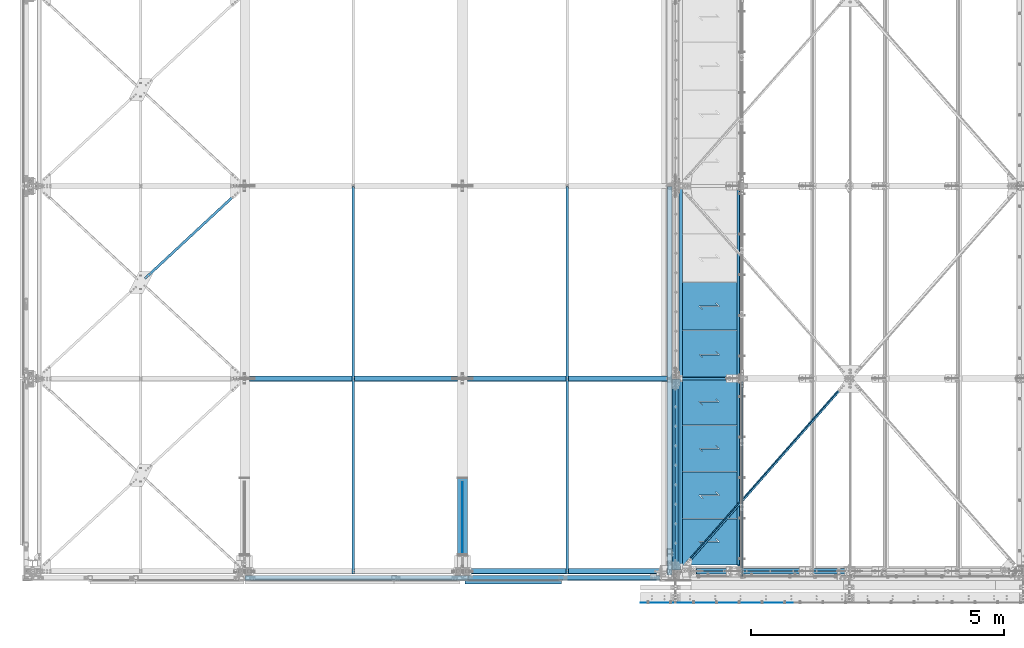
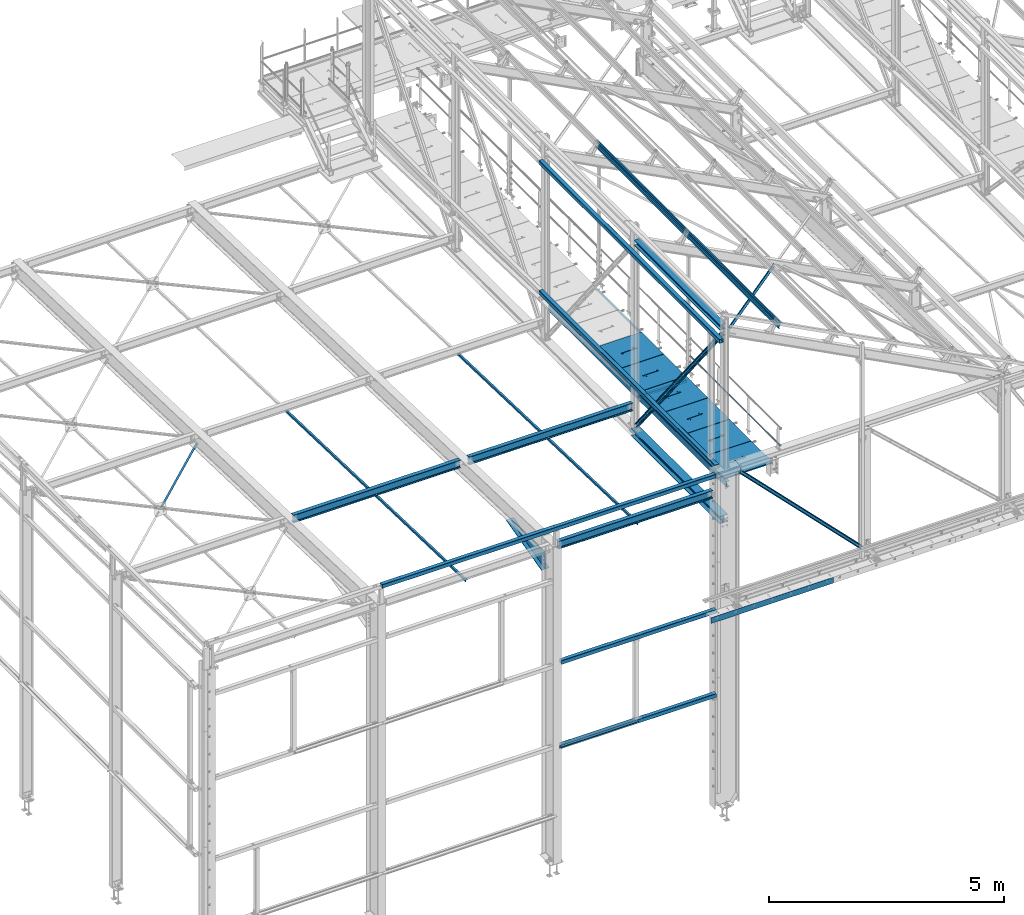
# One storey, part 42 of 496: 29 beams, 4 members, 31 elements without a shape of their own.
"""IFC2X3 building model written with IfcOpenShell, lengths in millimetres."""

from ifc_helpers import new_model, si_unit, frame, origin_with_axes, origin_2d_with_axis, place, context, subcontext, project, spatial, polyline, rectangle, hollow_rectangle, hollow_circle, i_section, l_section, u_section, outline, extrude, boolean, clip, halfspace, material, type_object, element, aggregate, save


model = new_model("IFC2X3")

# Units and contexts
model_context = context("Model", 3, precision=1e-05, world=origin_with_axes())
body_context = subcontext(model_context, "Body", "Model", "MODEL_VIEW")
ifc_project = project(units=[si_unit("LENGTHUNIT", "METRE", prefix="MILLI"), si_unit("AREAUNIT", "SQUARE_METRE"), si_unit("VOLUMEUNIT", "CUBIC_METRE"), si_unit("MASSUNIT", "GRAM", prefix="KILO"), si_unit("TIMEUNIT", "SECOND"), si_unit("PLANEANGLEUNIT", "RADIAN"), si_unit("SOLIDANGLEUNIT", "STERADIAN"), si_unit("THERMODYNAMICTEMPERATUREUNIT", "DEGREE_CELSIUS"), si_unit("LUMINOUSINTENSITYUNIT", "LUMEN")], contexts=[model_context])

# Site, building, storey
site_placement = place(None, origin_with_axes())
site = spatial("IfcSite", under=ifc_project, at=site_placement, CompositionType="ELEMENT")
building_placement = place(site_placement, origin_with_axes())
building = spatial("IfcBuilding", under=site, at=building_placement, Name="Undefined", CompositionType="ELEMENT")
storey_placement = place(building_placement, origin_with_axes())
storey = spatial("IfcBuildingStorey", under=building, at=storey_placement, Name="Undefined", CompositionType="ELEMENT", Elevation=0.0)

# Assembly, beam
assembly_1_placement = place(storey_placement, origin_with_axes())
assembly_1 = element("IfcElementAssembly", 1, at=assembly_1_placement, inside=storey, AssemblyPlace="NOTDEFINED", PredefinedType="NOTDEFINED")
ifc_material_1 = material(Name="Undefined/S235-E24")
beam_type_1 = type_object("IfcBeamType", PredefinedType="NOTDEFINED")
beam_1_placement = place(assembly_1_placement, frame((10543.7500126668, -53.9015129582931, 7826.58977123146), z_axis=(1.0, 0.0, 0.0), x_axis=(0.0, 0.999506556345274, -0.0314108870109058)))
beam_1 = element("IfcBeam", 2, at=beam_1_placement, type_object=beam_type_1, material=ifc_material_1, context=body_context, shape_type="SweptSolid", body=[
    extrude(l_section(Depth=50.0, Width=50.0, Thickness=5.0, FilletRadius=7.0, EdgeRadius=3.5, at=origin_2d_with_axis()), frame((7648.75199419146, 0.0, 0.0), z_axis=(-1.0, 0.0, 0.0), x_axis=(0.0, -1.0, 0.0)), (0.0, 0.0, 1.0), 7648.75),
])
aggregate(assembly_1, [beam_1])

assembly_2_placement = place(storey_placement, origin_with_axes())
assembly_2 = element("IfcElementAssembly", 3, at=assembly_2_placement, inside=storey, AssemblyPlace="NOTDEFINED", PredefinedType="NOTDEFINED")
beam_2_placement = place(assembly_2_placement, frame((6327.00001266682, -53.9015129325035, 7826.58977123108), z_axis=(1.0, 0.0, 0.0), x_axis=(0.0, 0.999506556345274, -0.0314108870109058)))
beam_2 = element("IfcBeam", 4, at=beam_2_placement, type_object=beam_type_1, material=ifc_material_1, context=body_context, shape_type="SweptSolid", body=[
    extrude(l_section(Depth=50.0, Width=50.0, Thickness=5.0, FilletRadius=7.0, EdgeRadius=3.5, at=origin_2d_with_axis()), frame((7648.75199419146, 0.0, 0.0), z_axis=(-1.0, 0.0, 0.0), x_axis=(0.0, -1.0, 0.0)), (0.0, 0.0, 1.0), 7648.75),
])
aggregate(assembly_2, [beam_2])

assembly_3_placement = place(storey_placement, origin_with_axes())
assembly_3 = element("IfcElementAssembly", 5, at=assembly_3_placement, inside=storey, AssemblyPlace="NOTDEFINED", PredefinedType="NOTDEFINED")
beam_3_placement = place(assembly_3_placement, frame((2132.95531990754, 5698.0833135148, 7639.81379578881), z_axis=(0.68083649638077, -0.732074010915111, 0.0230066889973314), x_axis=(0.732435434147601, 0.680500577137136, -0.0213845580043096)))
beam_3 = element("IfcBeam", 6, at=beam_3_placement, type_object=beam_type_1, material=ifc_material_1, context=body_context, shape_type="Clipping", body=[
    clip(clip(extrude(l_section(Depth=50.0, Width=50.0, Thickness=5.0, FilletRadius=7.0, EdgeRadius=3.5, at=origin_2d_with_axis()), frame((2792.05794235951, 1.81898940354586e-12, 3.02412813152477e-13), z_axis=(-1.0, 0.0, 0.0), x_axis=(0.0, -1.0, 0.0)), (0.0, 0.0, 1.0), 2736.72), halfspace(frame((2629.6011678119, 24.9927799072184, 24.996908648503), z_axis=(0.999999999996028, -1.34644375832952e-06, -2.47632953655041e-06), x_axis=(-2.47633029222942e-06, -5.61239297092375e-07, -0.999999999996776)), False)), halfspace(frame((106.894615079638, 31.0068168669877, 25.0000008156803), z_axis=(0.999999999998558, -1.69800000185205e-06, 0.0), x_axis=(1.69800000215235e-06, 0.999999999998558, 0.0)), True)),
])
aggregate(assembly_3, [beam_3])

assembly_4_placement = place(storey_placement, origin_with_axes())
assembly_4 = element("IfcElementAssembly", 7, at=assembly_4_placement, inside=storey, Name="SUPPORT", AssemblyPlace="NOTDEFINED", PredefinedType="NOTDEFINED")
beam_4_placement = place(assembly_4_placement, frame((13921.4998852159, 7595.00000000005, 8075.0), z_axis=(-1.0, 0.0, 0.0), x_axis=(0.0, -1.0, 0.0)))
beam_4 = element("IfcBeam", 8, at=beam_4_placement, type_object=beam_type_1, material=ifc_material_1, Name="SUPPORT", context=body_context, shape_type="SweptSolid", body=[
    extrude(l_section(Depth=50.0, Width=50.0, Thickness=5.0, FilletRadius=7.0, EdgeRadius=3.5, at=origin_2d_with_axis()), frame((7469.99998569226, 0.0, 0.0), z_axis=(-1.0, 0.0, 0.0), x_axis=(0.0, -1.0, 0.0)), (0.0, 0.0, 1.0), 7470.0),
])
aggregate(assembly_4, [beam_4])

assembly_5_placement = place(storey_placement, origin_with_axes())
assembly_5 = element("IfcElementAssembly", 9, at=assembly_5_placement, inside=storey, AssemblyPlace="NOTDEFINED", PredefinedType="NOTDEFINED")
beam_type_2 = type_object("IfcBeamType", PredefinedType="NOTDEFINED")
beam_5_placement = place(assembly_5_placement, frame((16127.0203970592, 3802.11476283256, 10301.8376747287), z_axis=(0.628485348147475, -0.704921073698757, -0.328774158077149), x_axis=(-0.624617894277257, -0.709285753314833, 0.326750985145042)))
beam_5 = element("IfcBeam", 10, at=beam_5_placement, type_object=beam_type_2, material=ifc_material_1, context=body_context, shape_type="Clipping", body=[
    clip(clip(extrude(l_section(Depth=60.0, Width=60.0, Thickness=6.0, FilletRadius=8.0, EdgeRadius=4.0, at=origin_2d_with_axis()), frame((5268.62291314195, -4.3870098496784e-13, -3.93044613040361e-12), z_axis=(-1.0, 0.0, 0.0), x_axis=(0.0, -1.0, 0.0)), (0.0, 0.0, 1.0), 5179.74), halfspace(frame((5188.72410921679, 29.9999246430962, 30.000000521487), z_axis=(-1.0, 0.0, 0.0), x_axis=(0.0, -1.0, 0.0)), True)), halfspace(frame((168.778057010568, 29.9999474878132, -29.9999995137009), z_axis=(1.0, 0.0, 0.0), x_axis=(0.0, -1.0, 0.0)), True)),
])
aggregate(assembly_5, [beam_5])

assembly_6_placement = place(storey_placement, origin_with_axes())
assembly_6 = element("IfcElementAssembly", 11, at=assembly_6_placement, inside=storey, Name="SUPPORT", AssemblyPlace="NOTDEFINED", PredefinedType="NOTDEFINED")
beam_type_3 = type_object("IfcBeamType", PredefinedType="NOTDEFINED")
beam_6_placement = place(assembly_6_placement, frame((11990.0, -622.0, 5154.99824538435), z_axis=(0.0, 0.0, 1.0), x_axis=(1.0, 0.0, 0.0)))
beam_6 = element("IfcBeam", 12, at=beam_6_placement, type_object=beam_type_3, material=ifc_material_1, Name="SUPPORT", context=body_context, shape_type="SweptSolid", body=[
    extrude(rectangle(XDim=4.0, YDim=150.0, at=origin_2d_with_axis()), frame((2999.99999402831, 0.0, 0.0), z_axis=(-1.0, 0.0, 0.0), x_axis=(0.0, -1.0, 0.0)), (0.0, 0.0, 1.0), 3000.0),
])
aggregate(assembly_6, [beam_6])

assembly_7_placement = place(storey_placement, origin_with_axes())
assembly_7 = element("IfcElementAssembly", 13, at=assembly_7_placement, inside=storey, Name="LISSE", AssemblyPlace="NOTDEFINED", PredefinedType="NOTDEFINED")
beam_type_4 = type_object("IfcBeamType", PredefinedType="NOTDEFINED")
beam_7_placement = place(assembly_7_placement, frame((4185.0, -130.0, 8500.0), z_axis=(0.0, 0.0, 1.0), x_axis=(1.0, 0.0, 0.0)))
beam_7 = element("IfcBeam", 14, at=beam_7_placement, type_object=beam_type_4, material=ifc_material_1, Name="LISSE", context=body_context, shape_type="SweptSolid", body=[
    extrude(hollow_rectangle(XDim=100.0, YDim=100.0, WallThickness=4.0, InnerFilletRadius=4.0, OuterFilletRadius=8.0, at=origin_2d_with_axis()), frame((8185.0, 0.0, 0.0), z_axis=(-1.0, 0.0, 0.0), x_axis=(0.0, -1.0, 0.0)), (0.0, 0.0, 1.0), 8185.0),
])
aggregate(assembly_7, [beam_7])

assembly_8_placement = place(storey_placement, origin_with_axes())
assembly_8 = element("IfcElementAssembly", 15, at=assembly_8_placement, inside=storey, Name="LISSE", AssemblyPlace="NOTDEFINED", PredefinedType="NOTDEFINED")
beam_8_placement = place(assembly_8_placement, frame((12563.5000013656, -70.000000986277, 11869.999999999), z_axis=(0.0, 0.0, -1.0), x_axis=(0.0, 1.0, 0.0)))
beam_8 = element("IfcBeam", 16, at=beam_8_placement, type_object=beam_type_4, material=ifc_material_1, Name="LISSE", context=body_context, shape_type="SweptSolid", body=[
    extrude(hollow_rectangle(XDim=100.0, YDim=100.0, WallThickness=4.0, InnerFilletRadius=4.0, OuterFilletRadius=8.0, at=origin_2d_with_axis()), frame((7664.99999999271, 0.0, 0.0), z_axis=(-1.0, 0.0, 0.0), x_axis=(0.0, -1.0, 0.0)), (0.0, 0.0, 1.0), 7665.0),
])
aggregate(assembly_8, [beam_8])

assembly_9_placement = place(storey_placement, origin_with_axes())
assembly_9 = element("IfcElementAssembly", 17, at=assembly_9_placement, inside=storey, Name="LISSE", AssemblyPlace="NOTDEFINED", PredefinedType="NOTDEFINED")
beam_9_placement = place(assembly_9_placement, frame((8585.00000000012, -130.000008285082, 4989.99999999904), z_axis=(0.0, 0.0, 1.0), x_axis=(1.0, 0.0, 0.0)))
beam_9 = element("IfcBeam", 18, at=beam_9_placement, type_object=beam_type_4, material=ifc_material_1, Name="LISSE", context=body_context, shape_type="SweptSolid", body=[
    extrude(hollow_rectangle(XDim=100.0, YDim=100.0, WallThickness=4.0, InnerFilletRadius=4.0, OuterFilletRadius=8.0, at=origin_2d_with_axis()), frame((3790.00000005984, 0.0, 0.0), z_axis=(-1.0, 0.0, 0.0), x_axis=(0.0, -1.0, 0.0)), (0.0, 0.0, 1.0), 3790.0),
])
aggregate(assembly_9, [beam_9])

assembly_10_placement = place(storey_placement, origin_with_axes())
assembly_10 = element("IfcElementAssembly", 19, at=assembly_10_placement, inside=storey, Name="LISSE", AssemblyPlace="NOTDEFINED", PredefinedType="NOTDEFINED")
beam_10_placement = place(assembly_10_placement, frame((8585.00000011466, -129.999999585804, 2810.0), z_axis=(0.0, 0.0, -1.0), x_axis=(1.0, 0.0, 0.0)))
beam_10 = element("IfcBeam", 20, at=beam_10_placement, type_object=beam_type_4, material=ifc_material_1, Name="LISSE", context=body_context, shape_type="SweptSolid", body=[
    extrude(hollow_rectangle(XDim=100.0, YDim=100.0, WallThickness=4.0, InnerFilletRadius=4.0, OuterFilletRadius=8.0, at=origin_2d_with_axis()), frame((3790.00000005984, 0.0, 0.0), z_axis=(-1.0, 0.0, 0.0), x_axis=(0.0, -1.0, 0.0)), (0.0, 0.0, 1.0), 3790.0),
])

assembly_11_placement = place(storey_placement, origin_with_axes())
assembly_11 = element("IfcElementAssembly", 21, at=assembly_11_placement, inside=storey, Name="LISSE", AssemblyPlace="NOTDEFINED", PredefinedType="NOTDEFINED")
beam_11_placement = place(assembly_11_placement, frame((12563.5000000138, 119.999999991442, 8499.99999999993), z_axis=(0.0, 0.0, 1.0), x_axis=(0.0, 1.0, 0.0)))
beam_11 = element("IfcBeam", 22, at=beam_11_placement, type_object=beam_type_4, material=ifc_material_1, Name="LISSE", context=body_context, shape_type="SweptSolid", body=[
    extrude(hollow_rectangle(XDim=100.0, YDim=100.0, WallThickness=4.0, InnerFilletRadius=4.0, OuterFilletRadius=8.0, at=origin_2d_with_axis()), frame((7475.00000000851, 0.0, 0.0), z_axis=(-1.0, 0.0, 0.0), x_axis=(0.0, -1.0, 0.0)), (0.0, 0.0, 1.0), 7475.0),
])
aggregate(assembly_11, [beam_11])

assembly_12_placement = place(storey_placement, origin_with_axes())
assembly_12 = element("IfcElementAssembly", 23, at=assembly_12_placement, inside=storey, AssemblyPlace="NOTDEFINED", PredefinedType="NOTDEFINED")
beam_type_5 = type_object("IfcBeamType", PredefinedType="NOTDEFINED")
beam_12_placement = place(assembly_12_placement, frame((13936.4998935003, 1035.00001430779, 8115.0), z_axis=(0.0, 0.0, 1.0), x_axis=(-1.0, 0.0, 0.0)))
beam_12 = element("IfcBeam", 24, at=beam_12_placement, type_object=beam_type_5, material=ifc_material_1, context=body_context, shape_type="CSG", body=[
    boolean("DIFFERENCE", extrude(outline(polyline([(0.0, 0.0), (1179.99169921875, 0.0), (1179.99169921875, 910.0), (-9.39995516091585e-07, 910.0), (0.0, 0.0)])), frame((0.0, 0.0, -15.0), z_axis=(0.0, 0.0, 1.0), x_axis=(1.0, 0.0, 0.0)), (0.0, 0.0, 1.0), 30.0), extrude(outline(polyline([(0.0, 0.0), (9.99999999997453, 6.91215973347425e-11), (10.0000000004329, 75.8578643791443), (282.842712400121, -196.984848017997), (282.842712400743, -96.9848480190813), (272.842712400776, -96.9848480191613), (272.842712400299, -172.842712398218), (0.0, 100.0), (0.0, 0.0)])), frame((724.285170968404, 520.710678119967, -17.5), z_axis=(0.0, 0.0, 1.0), x_axis=(-0.707106781186457, -0.707106781186639, 0.0)), (0.0, 0.0, 1.0), 35.0)),
])
aggregate(assembly_12, [beam_12])

assembly_13_placement = place(storey_placement, origin_with_axes())
assembly_13 = element("IfcElementAssembly", 25, at=assembly_13_placement, inside=storey, AssemblyPlace="NOTDEFINED", PredefinedType="NOTDEFINED")
beam_13_placement = place(assembly_13_placement, frame((13936.4998935003, 1955.00000953853, 8115.0), z_axis=(0.0, 0.0, 1.0), x_axis=(-1.0, 0.0, 0.0)))
beam_13 = element("IfcBeam", 26, at=beam_13_placement, type_object=beam_type_5, material=ifc_material_1, context=body_context, shape_type="CSG", body=[
    boolean("DIFFERENCE", extrude(outline(polyline([(0.0, 0.0), (1179.99169921875, 0.0), (1179.99169921875, 910.0), (-9.39995516091585e-07, 910.0), (0.0, 0.0)])), frame((0.0, 0.0, -15.0), z_axis=(0.0, 0.0, 1.0), x_axis=(1.0, 0.0, 0.0)), (0.0, 0.0, 1.0), 30.0), extrude(outline(polyline([(0.0, 0.0), (9.99999999997453, 6.91215973347425e-11), (10.0000000004329, 75.8578643791443), (282.842712400121, -196.984848017997), (282.842712400743, -96.9848480190813), (272.842712400776, -96.9848480191613), (272.842712400299, -172.842712398218), (0.0, 100.0), (0.0, 0.0)])), frame((724.285170968404, 520.710678119967, -17.5), z_axis=(0.0, 0.0, 1.0), x_axis=(-0.707106781186457, -0.707106781186639, 0.0)), (0.0, 0.0, 1.0), 35.0)),
])
aggregate(assembly_13, [beam_13])

assembly_14_placement = place(storey_placement, origin_with_axes())
assembly_14 = element("IfcElementAssembly", 27, at=assembly_14_placement, inside=storey, AssemblyPlace="NOTDEFINED", PredefinedType="NOTDEFINED")
beam_14_placement = place(assembly_14_placement, frame((13936.4998935003, 2875.00000476926, 8115.0), z_axis=(0.0, 0.0, 1.0), x_axis=(-1.0, 0.0, 0.0)))
beam_14 = element("IfcBeam", 28, at=beam_14_placement, type_object=beam_type_5, material=ifc_material_1, context=body_context, shape_type="CSG", body=[
    boolean("DIFFERENCE", extrude(outline(polyline([(0.0, 0.0), (1179.99169921875, 0.0), (1179.99169921875, 910.0), (-9.39995516091585e-07, 910.0), (0.0, 0.0)])), frame((0.0, 0.0, -15.0), z_axis=(0.0, 0.0, 1.0), x_axis=(1.0, 0.0, 0.0)), (0.0, 0.0, 1.0), 30.0), extrude(outline(polyline([(0.0, 0.0), (9.99999999997453, 6.91215973347425e-11), (10.0000000004329, 75.8578643791443), (282.842712400121, -196.984848017997), (282.842712400743, -96.9848480190813), (272.842712400776, -96.9848480191613), (272.842712400299, -172.842712398218), (0.0, 100.0), (0.0, 0.0)])), frame((724.285170968404, 520.710678119967, -17.5), z_axis=(0.0, 0.0, 1.0), x_axis=(-0.707106781186457, -0.707106781186639, 0.0)), (0.0, 0.0, 1.0), 35.0)),
])
aggregate(assembly_14, [beam_14])

assembly_15_placement = place(storey_placement, origin_with_axes())
assembly_15 = element("IfcElementAssembly", 29, at=assembly_15_placement, inside=storey, AssemblyPlace="NOTDEFINED", PredefinedType="NOTDEFINED")
beam_15_placement = place(assembly_15_placement, frame((13936.4998935003, 3795.0, 8115.0), z_axis=(0.0, 0.0, 1.0), x_axis=(-1.0, 0.0, 0.0)))
beam_15 = element("IfcBeam", 30, at=beam_15_placement, type_object=beam_type_5, material=ifc_material_1, context=body_context, shape_type="CSG", body=[
    boolean("DIFFERENCE", extrude(outline(polyline([(0.0, 0.0), (1179.99169921875, 0.0), (1179.99169921875, 910.0), (-9.39995516091585e-07, 910.0), (0.0, 0.0)])), frame((0.0, 0.0, -15.0), z_axis=(0.0, 0.0, 1.0), x_axis=(1.0, 0.0, 0.0)), (0.0, 0.0, 1.0), 30.0), extrude(outline(polyline([(0.0, 0.0), (9.99999999997453, 6.91215973347425e-11), (10.0000000004329, 75.8578643791443), (282.842712400121, -196.984848017997), (282.842712400743, -96.9848480190813), (272.842712400776, -96.9848480191613), (272.842712400299, -172.842712398218), (0.0, 100.0), (0.0, 0.0)])), frame((724.285170968404, 520.710678119967, -17.5), z_axis=(0.0, 0.0, 1.0), x_axis=(-0.707106781186457, -0.707106781186639, 0.0)), (0.0, 0.0, 1.0), 35.0)),
])
aggregate(assembly_15, [beam_15])

assembly_16_placement = place(storey_placement, origin_with_axes())
assembly_16 = element("IfcElementAssembly", 31, at=assembly_16_placement, inside=storey, AssemblyPlace="NOTDEFINED", PredefinedType="NOTDEFINED")
beam_type_6 = type_object("IfcBeamType", PredefinedType="NOTDEFINED")
beam_16_placement = place(assembly_16_placement, frame((13936.4998764003, 4744.99999523074, 8115.0), z_axis=(0.0, 0.0, 1.0), x_axis=(-1.0, 0.0, 0.0)))
beam_16 = element("IfcBeam", 32, at=beam_16_placement, type_object=beam_type_6, material=ifc_material_1, context=body_context, shape_type="CSG", body=[
    boolean("DIFFERENCE", extrude(outline(polyline([(0.0, 0.0), (1179.99169921875, 0.0), (1179.99169921875, 940.0), (-9.39995516091585e-07, 940.0), (0.0, 0.0)])), frame((0.0, 0.0, -15.0), z_axis=(0.0, 0.0, 1.0), x_axis=(1.0, 0.0, 0.0)), (0.0, 0.0, 1.0), 30.0), extrude(outline(polyline([(0.0, 0.0), (9.99999999997453, 6.91215973347425e-11), (10.0000000004329, 75.8578643791443), (282.842712400121, -196.984848017997), (282.842712400743, -96.9848480190813), (272.842712400776, -96.9848480191613), (272.842712400299, -172.842712398218), (0.0, 100.0), (0.0, 0.0)])), frame((724.286946489367, 535.710676888644, -17.5), z_axis=(0.0, 0.0, 1.0), x_axis=(-0.707106781186457, -0.707106781186639, 0.0)), (0.0, 0.0, 1.0), 35.0)),
])
aggregate(assembly_16, [beam_16])

assembly_17_placement = place(storey_placement, origin_with_axes())
assembly_17 = element("IfcElementAssembly", 33, at=assembly_17_placement, inside=storey, AssemblyPlace="NOTDEFINED", PredefinedType="NOTDEFINED")
beam_17_placement = place(assembly_17_placement, frame((13936.4998821003, 5694.99999523074, 8115.0), z_axis=(0.0, 0.0, 1.0), x_axis=(-1.0, 0.0, 0.0)))
beam_17 = element("IfcBeam", 34, at=beam_17_placement, type_object=beam_type_6, material=ifc_material_1, context=body_context, shape_type="CSG", body=[
    boolean("DIFFERENCE", extrude(outline(polyline([(0.0, 0.0), (1179.99169921875, 0.0), (1179.99169921875, 940.0), (-9.39995516091585e-07, 940.0), (0.0, 0.0)])), frame((0.0, 0.0, -15.0), z_axis=(0.0, 0.0, 1.0), x_axis=(1.0, 0.0, 0.0)), (0.0, 0.0, 1.0), 30.0), extrude(outline(polyline([(0.0, 0.0), (9.99999999997453, 6.91215973347425e-11), (10.0000000004329, 75.8578643791443), (282.842712400121, -196.984848017997), (282.842712400743, -96.9848480190813), (272.842712400776, -96.9848480191613), (272.842712400299, -172.842712398218), (0.0, 100.0), (0.0, 0.0)])), frame((724.286946489367, 535.710676888644, -17.5), z_axis=(0.0, 0.0, 1.0), x_axis=(-0.707106781186457, -0.707106781186639, 0.0)), (0.0, 0.0, 1.0), 35.0)),
])
aggregate(assembly_17, [beam_17])

# Beam
beam_type_7 = type_object("IfcBeamType", PredefinedType="NOTDEFINED")
beam_18_placement = place(assembly_10_placement, frame((8529.99999996897, -215.000007684151, 2825.0), z_axis=(0.0, -1.0, 0.0), x_axis=(1.0, 0.0, 0.0)))
beam_18 = element("IfcBeam", 35, at=beam_18_placement, type_object=beam_type_7, material=ifc_material_1, Name="SUPPORT", context=body_context, shape_type="SweptSolid", body=[
    extrude(l_section(Depth=70.0, Width=70.0, Thickness=7.0, FilletRadius=9.0, EdgeRadius=4.5, at=origin_2d_with_axis()), frame((1899.99781571392, 0.0, 0.0), z_axis=(-1.0, 0.0, 0.0), x_axis=(0.0, -1.0, 0.0)), (0.0, 0.0, 1.0), 1900.0),
])

aggregate(assembly_10, [beam_18, beam_10])

# Assembly, beam
assembly_18_placement = place(storey_placement, origin_with_axes())
assembly_18 = element("IfcElementAssembly", 36, at=assembly_18_placement, inside=storey, Name="TRAVERSE", AssemblyPlace="NOTDEFINED", PredefinedType="NOTDEFINED")
beam_type_8 = type_object("IfcBeamType", PredefinedType="NOTDEFINED")
beam_19_placement = place(assembly_18_placement, frame((8480.0, 1836.15791643143, 7534.87805845615), z_axis=(1.0, 0.0, 0.0), x_axis=(0.0, -0.967446195634957, -0.253076783904507)))
beam_19 = element("IfcBeam", 37, at=beam_19_placement, type_object=beam_type_8, material=ifc_material_1, context=body_context, shape_type="SweptSolid", body=[
    extrude(rectangle(XDim=15.0, YDim=190.0, at=origin_2d_with_axis()), frame((1549.7087562475, 0.0, 0.0), z_axis=(-1.0, 0.0, 0.0), x_axis=(0.0, -1.0, 0.0)), (0.0, 0.0, 1.0), 1549.71),
])

assembly_19_placement = place(storey_placement, origin_with_axes())
assembly_19 = element("IfcElementAssembly", 38, at=assembly_19_placement, inside=storey, Name="MAIN COURANTE", AssemblyPlace="NOTDEFINED", PredefinedType="NOTDEFINED")
beam_type_9 = type_object("IfcBeamType", PredefinedType="NOTDEFINED")
beam_20_placement = place(assembly_19_placement, frame((13993.9998855574, 3745.00000944063, 8673.80000478163), z_axis=(0.0, 0.0, 1.0), x_axis=(0.0, -1.0, 0.0)))
beam_20 = element("IfcBeam", 39, at=beam_20_placement, type_object=beam_type_9, material=ifc_material_1, Name="LISSE", context=body_context, shape_type="SweptSolid", body=[
    extrude(hollow_circle(Radius=13.44999981, WallThickness=2.0, at=origin_2d_with_axis()), frame((3844.99656169932, 3.84499533570735e-24, 0.0), z_axis=(-1.0, 0.0, 0.0), x_axis=(0.0, -1.0, 0.0)), (0.0, 0.0, 1.0), 3845.0),
])
aggregate(assembly_19, [beam_20])

assembly_20_placement = place(storey_placement, origin_with_axes())
assembly_20 = element("IfcElementAssembly", 40, at=assembly_20_placement, inside=storey, AssemblyPlace="NOTDEFINED", PredefinedType="NOTDEFINED")
ifc_material_2 = material(Name="Undefined/S275-E28")
beam_type_10 = type_object("IfcBeamType", Name="HEA140", PredefinedType="NOTDEFINED")
beam_21_placement = place(assembly_20_placement, frame((12683.5, 3725.0, 12103.5), z_axis=(0.0, 0.0, 1.0), x_axis=(0.0, -1.0, 0.0)))
beam_21 = element("IfcBeam", 41, at=beam_21_placement, type_object=beam_type_10, material=ifc_material_2, ObjectType="HEA140", context=body_context, shape_type="SweptSolid", body=[
    extrude(i_section(OverallWidth=140.0, OverallDepth=133.0, WebThickness=5.5, FlangeThickness=8.5, FilletRadius=12.0, at=origin_2d_with_axis()), frame((3650.0, 0.0, 0.0), z_axis=(-1.0, 0.0, 0.0), x_axis=(0.0, -1.0, 0.0)), (0.0, 0.0, 1.0), 3650.0),
])
aggregate(assembly_20, [beam_21])

assembly_21_placement = place(storey_placement, origin_with_axes())
assembly_21 = element("IfcElementAssembly", 42, at=assembly_21_placement, inside=storey, AssemblyPlace="NOTDEFINED", PredefinedType="NOTDEFINED")
beam_type_11 = type_object("IfcBeamType", Name="HEA200", PredefinedType="NOTDEFINED")
beam_22_placement = place(assembly_21_placement, frame((12679.9999999854, 3795.00000162412, 7154.99993592185), z_axis=(0.0, 0.0, 1.0), x_axis=(0.0, -1.0, 0.0)))
beam_22 = element("IfcBeam", 43, at=beam_22_placement, type_object=beam_type_11, material=ifc_material_2, ObjectType="HEA200", context=body_context, shape_type="SweptSolid", body=[
    extrude(i_section(OverallWidth=200.0, OverallDepth=190.0, WebThickness=6.5, FlangeThickness=10.0, FilletRadius=18.0, at=origin_2d_with_axis()), frame((3765.00000093111, 0.0, 0.0), z_axis=(-1.0, 0.0, 0.0), x_axis=(0.0, -1.0, 0.0)), (0.0, 0.0, 1.0), 3765.0),
])
aggregate(assembly_21, [beam_22])

assembly_22_placement = place(storey_placement, origin_with_axes())
assembly_22 = element("IfcElementAssembly", 44, at=assembly_22_placement, inside=storey, AssemblyPlace="NOTDEFINED", PredefinedType="NOTDEFINED")
beam_type_12 = type_object("IfcBeamType", PredefinedType="NOTDEFINED")
beam_23_placement = place(assembly_22_placement, frame((12781.5083416269, 20.000001010013, 8025.0), z_axis=(0.0, 0.0, 1.0), x_axis=(0.0, 1.0, 0.0)))
beam_23 = element("IfcBeam", 45, at=beam_23_placement, type_object=beam_type_12, material=ifc_material_1, context=body_context, shape_type="SweptSolid", body=[
    extrude(u_section(Depth=150.0, FlangeWidth=70.0, WebThickness=5.0, FlangeThickness=5.0, at=origin_2d_with_axis()), frame((7575.00000051288, 0.0, 0.0), z_axis=(-1.0, 0.0, 0.0), x_axis=(0.0, -1.0, 0.0)), (0.0, 0.0, 1.0), 7575.0),
])
aggregate(assembly_22, [beam_23])

assembly_23_placement = place(storey_placement, origin_with_axes())
assembly_23 = element("IfcElementAssembly", 46, at=assembly_23_placement, inside=storey, Name="SHED", AssemblyPlace="NOTDEFINED", PredefinedType="NOTDEFINED")
beam_type_13 = type_object("IfcBeamType", PredefinedType="NOTDEFINED")
beam_24_placement = place(assembly_23_placement, frame((13958.9855141407, -154.999920381521, 11830.980379482), z_axis=(0.46352885499701, 6.99999093634976e-09, 0.886081824994261), x_axis=(0.0, 1.0, 0.0)))
beam_24 = element("IfcBeam", 47, at=beam_24_placement, type_object=beam_type_13, material=ifc_material_1, Name="SHED", context=body_context, shape_type="SweptSolid", body=[
    extrude(outline(polyline([(-27.9999999860338, 36.0000000101354), (-27.999999986052, 70.0000000101354), (28.0000000138389, 70.0000000101209), (28.0000000138425, 58.0000000101209), (26.5000000138534, 58.0000000101209), (26.5000000138352, 68.5000000101172), (-26.4999999860593, 68.5000000101354), (-26.4999999860338, 36.7000007730749), (-1.49999998607018, 15.6999998194005), (-1.49999998605563, -15.6999997991297), (-26.4999999859974, -36.7000007527895), (-26.4999999859829, -68.49999998985), (26.5000000139153, -68.4999999898646), (26.500000013908, -57.9999999898646), (28.0000000139116, -57.9999999898646), (28.0000000139153, -69.9999999898646), (-27.9999999859756, -69.99999998985), (-27.9999999859901, -35.99999998985), (-2.99999998605927, -14.9999999898646), (-2.9999999860629, 15.0000000101354), (-27.9999999860338, 36.0000000101354)])), frame((7750.00000000006, -3.63797880548905e-12, 0.0), z_axis=(-1.0, 0.0, 0.0), x_axis=(0.0, -1.0, 0.0)), (0.0, 0.0, 1.0), 7750.0),
])
aggregate(assembly_23, [beam_24])

# Assembly, member
assembly_24_placement = place(storey_placement, origin_with_axes())
assembly_24 = element("IfcElementAssembly", 48, at=assembly_24_placement, inside=storey, AssemblyPlace="NOTDEFINED", PredefinedType="NOTDEFINED")
member_type = type_object("IfcMemberType", Name="UPN80", PredefinedType="NOTDEFINED")
member_1_placement = place(assembly_24_placement, frame((12707.5000000055, 3799.99999999888, 7250.0), z_axis=(0.0, -0.783226119129084, -0.621736959102476), x_axis=(0.0, -0.621736945771141, 0.783226129711702)))
member_1 = element("IfcMember", 49, at=member_1_placement, type_object=member_type, material=ifc_material_2, ObjectType="UPN80", context=body_context, shape_type="Clipping", body=[
    clip(clip(extrude(u_section(Depth=80.0, FlangeWidth=45.0, WebThickness=6.0, FlangeThickness=8.0, FilletRadius=8.0, EdgeRadius=4.0, FlangeSlope=0.0798299857122373, at=origin_2d_with_axis()), frame((6070.59328113819, 0.0, -6.73971243385439e-13), z_axis=(-1.0, 0.0, 0.0), x_axis=(0.0, -1.0, 0.0)), (0.0, 0.0, 1.0), 6029.29), halfspace(frame((5991.90044344031, 27.5000000054715, -39.9999959760762), z_axis=(-1.0, 0.0, 0.0), x_axis=(0.0, 1.0, 0.0)), True)), halfspace(frame((119.999999997919, 27.49999999375, -39.9999989691296), z_axis=(-1.0, 0.0, 0.0), x_axis=(0.0, 1.0, 0.0)), False)),
])
aggregate(assembly_24, [member_1])

assembly_25_placement = place(storey_placement, origin_with_axes())
assembly_25 = element("IfcElementAssembly", 50, at=assembly_25_placement, inside=storey, AssemblyPlace="NOTDEFINED", PredefinedType="NOTDEFINED")
member_2_placement = place(assembly_25_placement, frame((12652.4999999925, 0.00552230211962979, 12037.0), z_axis=(0.0, -0.783226119129084, -0.621736959102476), x_axis=(0.0, 0.621736959102476, -0.783226119129084)))
member_2 = element("IfcMember", 51, at=member_2_placement, type_object=member_type, material=ifc_material_2, ObjectType="UPN80", context=body_context, shape_type="Clipping", body=[
    clip(clip(extrude(u_section(Depth=80.0, FlangeWidth=45.0, WebThickness=6.0, FlangeThickness=8.0, FilletRadius=8.0, EdgeRadius=4.0, FlangeSlope=0.0798299857122373, at=origin_2d_with_axis()), frame((6070.59328113819, 0.0, -6.73971243385439e-13), z_axis=(-1.0, 0.0, 0.0), x_axis=(0.0, -1.0, 0.0)), (0.0, 0.0, 1.0), 6029.29), halfspace(frame((5991.90044344031, 27.5000000054715, -39.9999959760762), z_axis=(1.0, 0.0, 0.0), x_axis=(0.0, -1.0, 0.0)), False)), halfspace(frame((119.999999997919, 27.49999999375, -39.9999989691296), z_axis=(1.0, 0.0, 0.0), x_axis=(0.0, -1.0, 0.0)), True)),
])
aggregate(assembly_25, [member_2])

assembly_26_placement = place(storey_placement, origin_with_axes())
assembly_26 = element("IfcElementAssembly", 52, at=assembly_26_placement, inside=storey, AssemblyPlace="NOTDEFINED", PredefinedType="NOTDEFINED")
member_3_placement = place(assembly_26_placement, frame((12979.9982004448, 27.4999999945376, 8359.99916816148), z_axis=(-0.711050927851031, 0.0, -0.703140510852695), x_axis=(0.703140533980626, 0.0, -0.711050904980396)))
member_3 = element("IfcMember", 53, at=member_3_placement, type_object=member_type, material=ifc_material_2, ObjectType="UPN80", context=body_context, shape_type="Clipping", body=[
    clip(clip(extrude(u_section(Depth=80.0, FlangeWidth=45.0, WebThickness=6.0, FlangeThickness=8.0, FilletRadius=8.0, EdgeRadius=4.0, FlangeSlope=0.0798299857122373, at=origin_2d_with_axis()), frame((4418.98270887705, 3.5527136788005e-15, 0.0), z_axis=(-1.0, 0.0, 0.0), x_axis=(0.0, -1.0, 0.0)), (0.0, 0.0, 1.0), 4379.78), halfspace(frame((4338.18776487385, 27.4999999945376, 39.9999994263526), z_axis=(1.0, 0.0, 0.0), x_axis=(0.0, 1.0, 0.0)), False)), halfspace(frame((119.999999997919, 27.49999999375, -39.9999989691296), z_axis=(-1.0, 0.0, 0.0), x_axis=(0.0, 1.0, 0.0)), False)),
])
aggregate(assembly_26, [member_3])

assembly_27_placement = place(storey_placement, origin_with_axes())
assembly_27 = element("IfcElementAssembly", 54, at=assembly_27_placement, inside=storey, AssemblyPlace="NOTDEFINED", PredefinedType="NOTDEFINED")
member_4_placement = place(assembly_27_placement, frame((16114.7306905681, -27.5000000007276, 5190.00068831383), z_axis=(-0.711050927851031, 0.0, -0.703140510852695), x_axis=(-0.703140510852695, 0.0, 0.71105092785103)))
member_4 = element("IfcMember", 55, at=member_4_placement, type_object=member_type, material=ifc_material_2, ObjectType="UPN80", context=body_context, shape_type="Clipping", body=[
    clip(clip(extrude(u_section(Depth=80.0, FlangeWidth=45.0, WebThickness=6.0, FlangeThickness=8.0, FilletRadius=8.0, EdgeRadius=4.0, FlangeSlope=0.0798299857122373, at=origin_2d_with_axis()), frame((4418.98270887705, 3.5527136788005e-15, 0.0), z_axis=(-1.0, 0.0, 0.0), x_axis=(0.0, -1.0, 0.0)), (0.0, 0.0, 1.0), 4379.78), halfspace(frame((4338.18776489126, 27.5000000007276, -39.9999999999982), z_axis=(1.0, 0.0, 0.0), x_axis=(0.0, -1.0, 0.0)), False)), halfspace(frame((119.999999989826, 27.5000000297296, 39.9999985196016), z_axis=(-1.0, 0.0, 0.0), x_axis=(0.0, -1.0, 0.0)), False)),
])
aggregate(assembly_27, [member_4])

# Beam
beam_type_14 = type_object("IfcBeamType", PredefinedType="NOTDEFINED")
beam_25_placement = place(assembly_18_placement, frame((8480.0, 335.0, 7589.25004344064), z_axis=(-1.0, 0.0, 0.0), x_axis=(0.0, 0.999506556345274, -0.0314108870109058)))
beam_25 = element("IfcBeam", 56, at=beam_25_placement, type_object=beam_type_14, material=ifc_material_1, context=body_context, shape_type="SweptSolid", body=[
    extrude(outline(polyline([(0.942322762899387, 29.9851968112687), (30.0, 0.0), (1419.99999999984, -1.22432538773864e-09), (1423.27844149021, 22.6672111163732), (42.569691038819, 430.594491876205), (12.856783834807, 409.109499234062), (0.942322762899387, 29.9851968112687)])), frame((0.0, 0.0, -5.0), z_axis=(0.0, 0.0, 1.0), x_axis=(1.0, 0.0, 0.0)), (0.0, 0.0, 1.0), 10.0),
])

aggregate(assembly_18, [beam_25, beam_19])

# Assembly, beam
assembly_28_placement = place(storey_placement, origin_with_axes())
assembly_28 = element("IfcElementAssembly", 57, at=assembly_28_placement, inside=storey, AssemblyPlace="NOTDEFINED", PredefinedType="NOTDEFINED")
beam_type_15 = type_object("IfcBeamType", PredefinedType="NOTDEFINED")
beam_26_placement = place(assembly_28_placement, frame((12758.0001144705, 3800.0, 8015.0), z_axis=(0.0, -1.0, 0.0), x_axis=(1.0, 0.0, 0.0)))
beam_26 = element("IfcBeam", 58, at=beam_26_placement, type_object=beam_type_15, material=ifc_material_1, context=body_context, shape_type="SweptSolid", body=[
    extrude(hollow_rectangle(XDim=60.0, YDim=60.0, WallThickness=3.0, InnerFilletRadius=3.0, OuterFilletRadius=6.0, at=origin_2d_with_axis()), frame((1181.99977105896, 0.0, 0.0), z_axis=(-1.0, 0.0, 0.0), x_axis=(0.0, -1.0, 0.0)), (0.0, 0.0, 1.0), 1182.0),
])
aggregate(assembly_28, [beam_26])

assembly_29_placement = place(storey_placement, origin_with_axes())
assembly_29 = element("IfcElementAssembly", 59, at=assembly_29_placement, inside=storey, AssemblyPlace="NOTDEFINED", PredefinedType="NOTDEFINED")
beam_type_16 = type_object("IfcBeamType", Name="IPE200", PredefinedType="NOTDEFINED")
beam_27_placement = place(assembly_29_placement, frame((8579.99999999943, 3800.00552192617, 7830.53062122804), z_axis=(0.0, 0.031410887010906, 0.999506556345274), x_axis=(1.0, 0.0, 0.0)))
beam_27 = element("IfcBeam", 60, at=beam_27_placement, type_object=beam_type_16, material=ifc_material_2, ObjectType="IPE200", context=body_context, shape_type="SweptSolid", body=[
    extrude(i_section(OverallWidth=100.0, OverallDepth=200.0, WebThickness=5.599999905, FlangeThickness=8.5, FilletRadius=12.0, at=origin_2d_with_axis()), frame((4023.49999999568, 0.0, 0.0), z_axis=(-1.0, 0.0, 0.0), x_axis=(0.0, -1.0, 0.0)), (0.0, 0.0, 1.0), 4023.5),
])
aggregate(assembly_29, [beam_27])

assembly_30_placement = place(storey_placement, origin_with_axes())
assembly_30 = element("IfcElementAssembly", 61, at=assembly_30_placement, inside=storey, AssemblyPlace="NOTDEFINED", PredefinedType="NOTDEFINED")
beam_28_placement = place(assembly_30_placement, frame((4280.0, 3800.0055219241, 7830.53062122803), z_axis=(0.0, 0.031410887010906, 0.999506556345274), x_axis=(1.0, 0.0, 0.0)))
beam_28 = element("IfcBeam", 62, at=beam_28_placement, type_object=beam_type_16, material=ifc_material_2, ObjectType="IPE200", context=body_context, shape_type="SweptSolid", body=[
    extrude(i_section(OverallWidth=100.0, OverallDepth=200.0, WebThickness=5.599999905, FlangeThickness=8.5, FilletRadius=12.0, at=origin_2d_with_axis()), frame((4100.0, 0.0, 0.0), z_axis=(-1.0, 0.0, 0.0), x_axis=(0.0, -1.0, 0.0)), (0.0, 0.0, 1.0), 4100.0),
])
aggregate(assembly_30, [beam_28])

assembly_31_placement = place(storey_placement, origin_with_axes())
assembly_31 = element("IfcElementAssembly", 63, at=assembly_31_placement, inside=storey, AssemblyPlace="NOTDEFINED", PredefinedType="NOTDEFINED")
beam_29_placement = place(assembly_31_placement, frame((8580.0, 2.07000994123518e-09, 7949.95062448275), z_axis=(0.0, 0.031410887010906, 0.999506556345274), x_axis=(1.0, 0.0, 0.0)))
beam_29 = element("IfcBeam", 64, at=beam_29_placement, type_object=beam_type_16, material=ifc_material_2, ObjectType="IPE200", context=body_context, shape_type="SweptSolid", body=[
    extrude(i_section(OverallWidth=100.0, OverallDepth=200.0, WebThickness=5.599999905, FlangeThickness=8.5, FilletRadius=12.0, at=origin_2d_with_axis()), frame((3790.00000005984, 0.0, 0.0), z_axis=(-1.0, 0.0, 0.0), x_axis=(0.0, -1.0, 0.0)), (0.0, 0.0, 1.0), 3790.0),
])
aggregate(assembly_31, [beam_29])

save(model, "model.ifc")
